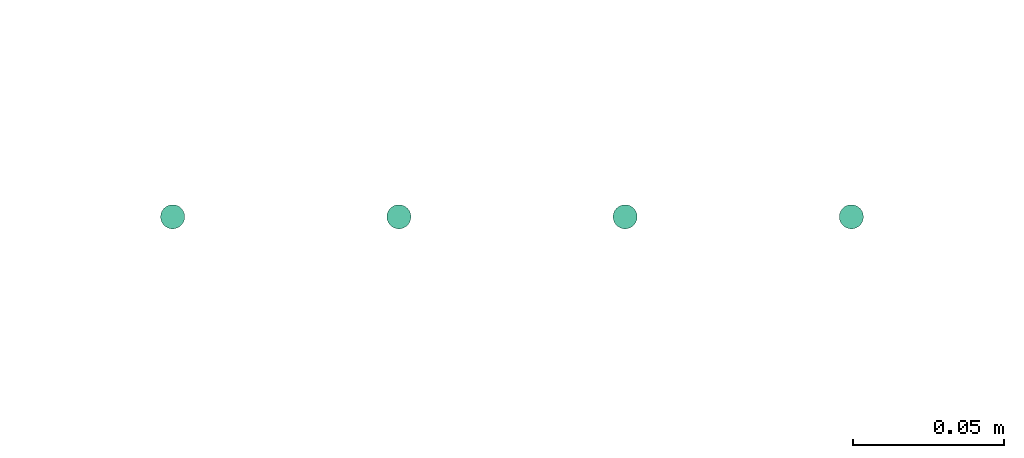
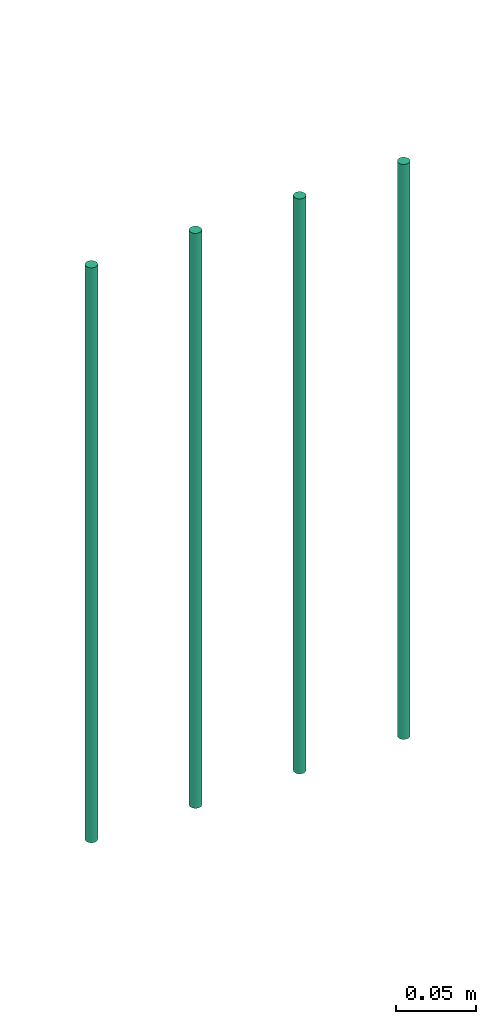
# One storey, part 34 of 65: 4 flow segments.
"""IFC2X3 building model written with IfcOpenShell, lengths in millimetres."""

from ifc_helpers import new_model, entity, si_unit, converted_unit, derived_unit, direction, frame, origin, origin_2d_with_axis, place, context, subcontext, project, spatial, circle, extrude, type_object, element, save


model = new_model("IFC2X3")

# Units and contexts
model_context = context("Model", 3, precision=0.01, world=origin(), true_north=direction((6.12303176911189e-17, 1.0)))
body_context = subcontext(model_context, "Body", "Model", "MODEL_VIEW")
ifc_project = project(units=[si_unit("LENGTHUNIT", "METRE", prefix="MILLI"), si_unit("AREAUNIT", "SQUARE_METRE"), si_unit("VOLUMEUNIT", "CUBIC_METRE"), converted_unit("PLANEANGLEUNIT", "DEGREE", entity("IfcRatioMeasure", 0.0174532925199433), si_unit("PLANEANGLEUNIT", "RADIAN"), dimensions=[0, 0, 0, 0, 0, 0, 0]), si_unit("MASSUNIT", "GRAM", prefix="KILO"), derived_unit("MASSDENSITYUNIT", [(si_unit("MASSUNIT", "GRAM", prefix="KILO"), 1), (si_unit("LENGTHUNIT", "METRE"), -3)]), derived_unit("MOMENTOFINERTIAUNIT", [(si_unit("LENGTHUNIT", "METRE"), 4)]), si_unit("TIMEUNIT", "SECOND"), si_unit("FREQUENCYUNIT", "HERTZ"), si_unit("THERMODYNAMICTEMPERATUREUNIT", "DEGREE_CELSIUS"), derived_unit("THERMALTRANSMITTANCEUNIT", [(si_unit("MASSUNIT", "GRAM", prefix="KILO"), 1), (si_unit("THERMODYNAMICTEMPERATUREUNIT", "KELVIN"), -1), (si_unit("TIMEUNIT", "SECOND"), -3)]), derived_unit("VOLUMETRICFLOWRATEUNIT", [(si_unit("LENGTHUNIT", "METRE"), 3), (si_unit("TIMEUNIT", "SECOND"), -1)]), derived_unit("MASSFLOWRATEUNIT", [(si_unit("MASSUNIT", "GRAM", prefix="KILO"), 1), (si_unit("TIMEUNIT", "SECOND"), -1)]), derived_unit("ROTATIONALFREQUENCYUNIT", [(si_unit("TIMEUNIT", "SECOND"), -1)]), si_unit("ELECTRICCURRENTUNIT", "AMPERE"), si_unit("ELECTRICVOLTAGEUNIT", "VOLT"), si_unit("POWERUNIT", "WATT"), si_unit("FORCEUNIT", "NEWTON", prefix="KILO"), si_unit("ILLUMINANCEUNIT", "LUX"), si_unit("LUMINOUSFLUXUNIT", "LUMEN"), si_unit("LUMINOUSINTENSITYUNIT", "CANDELA"), derived_unit("USERDEFINED", [(si_unit("MASSUNIT", "GRAM", prefix="KILO"), -1), (si_unit("LENGTHUNIT", "METRE"), -2), (si_unit("TIMEUNIT", "SECOND"), 3), (si_unit("LUMINOUSFLUXUNIT", "LUMEN"), 1)]), derived_unit("LINEARVELOCITYUNIT", [(si_unit("LENGTHUNIT", "METRE"), 1), (si_unit("TIMEUNIT", "SECOND"), -1)]), si_unit("PRESSUREUNIT", "PASCAL"), derived_unit("USERDEFINED", [(si_unit("LENGTHUNIT", "METRE"), -2), (si_unit("MASSUNIT", "GRAM", prefix="KILO"), 1), (si_unit("TIMEUNIT", "SECOND"), -2)]), derived_unit("LINEARFORCEUNIT", [(si_unit("MASSUNIT", "GRAM", prefix="KILO"), 1), (si_unit("LENGTHUNIT", "METRE"), 1), (si_unit("TIMEUNIT", "SECOND"), -2), (si_unit("LENGTHUNIT", "METRE"), -1)]), derived_unit("PLANARFORCEUNIT", [(si_unit("MASSUNIT", "GRAM", prefix="KILO"), 1), (si_unit("LENGTHUNIT", "METRE"), 1), (si_unit("TIMEUNIT", "SECOND"), -2), (si_unit("LENGTHUNIT", "METRE"), -2)])], contexts=[model_context])

# Site, building, storey
site_placement = place(None, frame((0.0, -0.00077364408347762, 0.0)))
site = spatial("IfcSite", under=ifc_project, at=site_placement, CompositionType="ELEMENT")
building_placement = place(site_placement, origin())
building = spatial("IfcBuilding", under=site, at=building_placement, CompositionType="ELEMENT")
storey_placement = place(building_placement, frame((0.0, 0.0, 19800.0)))
storey = spatial("IfcBuildingStorey", under=building, at=storey_placement, CompositionType="ELEMENT", Elevation=19800.0)

# Flow segments
pipe_segment_type = type_object("IfcPipeSegmentType", PredefinedType="NOTDEFINED")
flow_segment_1_placement = place(storey_placement, frame((34039.8822000101, 16317.65509256, -13005.0)))
element("IfcFlowSegment", 1, at=flow_segment_1_placement, inside=storey, type_object=pipe_segment_type, context=body_context, shape_type="SweptSolid", body=[
    extrude(circle(Radius=4.0, at=origin_2d_with_axis()), frame((5.59527223591499, 5.59527223591499, 0.0), z_axis=(0.0, 0.0, 1.0), x_axis=(-1.0, 0.0, 0.0)), (0.0, 0.0, 1.0), 438.000000000034),
])
flow_segment_2_placement = place(storey_placement, frame((34114.8822000101, 16317.65509256, -13005.0)))
element("IfcFlowSegment", 2, at=flow_segment_2_placement, inside=storey, type_object=pipe_segment_type, context=body_context, shape_type="SweptSolid", body=[
    extrude(circle(Radius=4.0, at=origin_2d_with_axis()), frame((5.59527223591499, 5.59527223591499, 0.0), z_axis=(0.0, 0.0, 1.0), x_axis=(-1.0, 0.0, 0.0)), (0.0, 0.0, 1.0), 438.000000000039),
])
for number, where in (
    (3, (34189.8822000101, 16317.65509256, -13005.0)),
    (4, (34264.8822000101, 16317.65509256, -13005.0)),
):
    element("IfcFlowSegment", number, at=place(storey_placement, frame(where)), inside=storey, type_object=pipe_segment_type, context=body_context, shape_type="SweptSolid", body=[
        extrude(circle(Radius=4.0, at=origin_2d_with_axis()), frame((5.59527223591499, 5.59527223591499, 0.0), z_axis=(0.0, 0.0, 1.0), x_axis=(-1.0, 0.0, 0.0)), (0.0, 0.0, 1.0), 438.000000000034),
    ])

save(model, "model.ifc")
